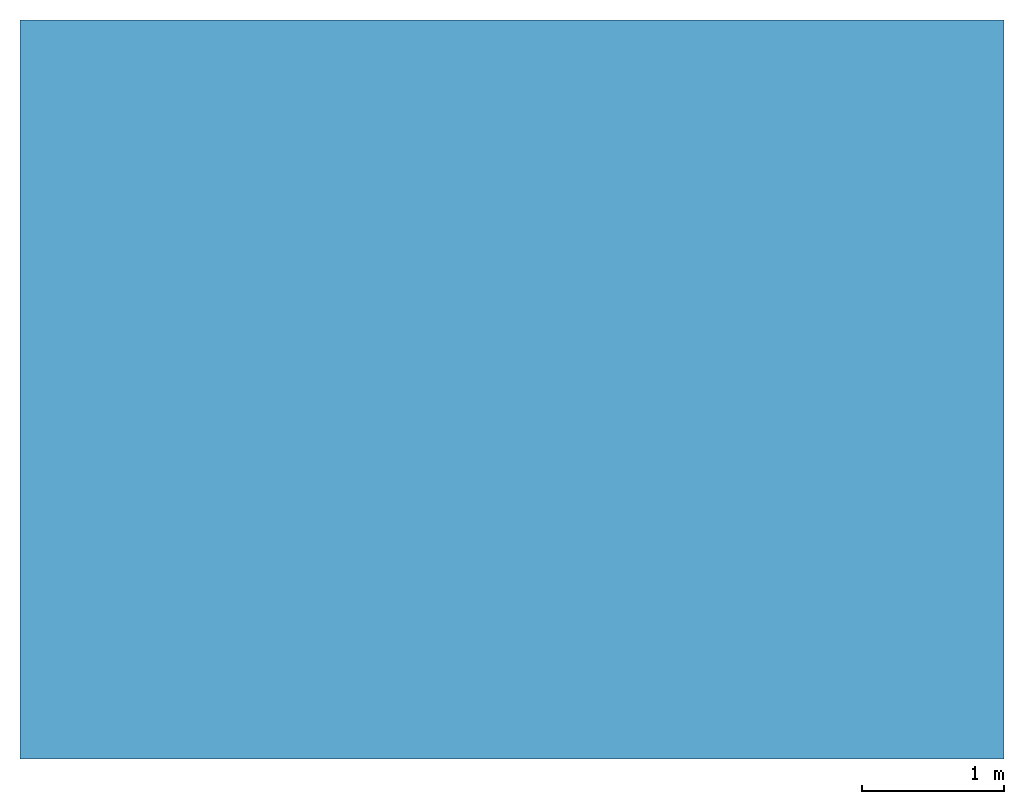
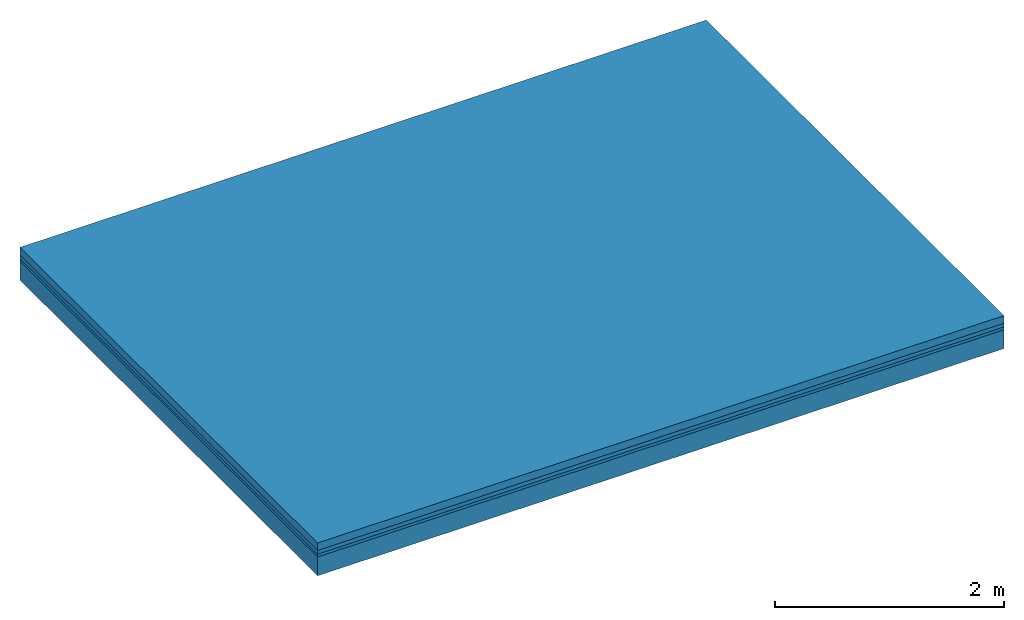
# One storey: 4 building element parts, 1 element without a shape of its own.
"""IFC2X3 building model written with IfcOpenShell, lengths in metres."""

from ifc_helpers import new_model, entity, si_unit, converted_unit, derived_unit, money_unit, direction, frame, origin_with_axes, place, context, subcontext, project, spatial, polyline, outline, extrude, material, type_object, element, aggregate, save


model = new_model("IFC2X3")

# Units and contexts
model_context = context("Model", 3, precision=1e-05, world=origin_with_axes(), true_north=direction((0.309016994375, 0.951056516295)))
body_context = subcontext(model_context, "Body", "Model", "MODEL_VIEW")
ifc_project = project(units=[si_unit("LENGTHUNIT", "METRE"), si_unit("AREAUNIT", "SQUARE_METRE"), si_unit("VOLUMEUNIT", "CUBIC_METRE"), converted_unit("PLANEANGLEUNIT", "DEGREE", entity("IfcPlaneAngleMeasure", 0.0174532925199), si_unit("PLANEANGLEUNIT", "RADIAN"), dimensions=[0, 0, 0, 0, 0, 0, 0]), si_unit("SOLIDANGLEUNIT", "STERADIAN"), money_unit("EUR"), si_unit("TIMEUNIT", "SECOND"), si_unit("MASSUNIT", "GRAM", prefix="KILO"), si_unit("THERMODYNAMICTEMPERATUREUNIT", "DEGREE_CELSIUS"), si_unit("LUMINOUSINTENSITYUNIT", "LUMEN"), si_unit("ENERGYUNIT", "JOULE", prefix="MEGA"), derived_unit("THERMALCONDUCTANCEUNIT", [(si_unit("POWERUNIT", "WATT"), 1), (si_unit("LENGTHUNIT", "METRE"), -1), (si_unit("THERMODYNAMICTEMPERATUREUNIT", "KELVIN"), -1)]), derived_unit("SPECIFICHEATCAPACITYUNIT", [(si_unit("ENERGYUNIT", "JOULE"), 1), (si_unit("MASSUNIT", "GRAM", prefix="KILO"), -1), (si_unit("THERMODYNAMICTEMPERATUREUNIT", "KELVIN"), -1)]), derived_unit("MASSDENSITYUNIT", [(si_unit("MASSUNIT", "GRAM", prefix="KILO"), 1), (si_unit("VOLUMEUNIT", "CUBIC_METRE"), -1)])], contexts=[model_context])

# Site, building, storey
site_placement = place(None, origin_with_axes())
site = spatial("IfcSite", under=ifc_project, at=site_placement, CompositionType="ELEMENT")
building_placement = place(site_placement, origin_with_axes())
building = spatial("IfcBuilding", under=site, at=building_placement, CompositionType="ELEMENT")
storey_placement = place(building_placement, frame((0.0, 0.0, -2.88), z_axis=(0.0, 0.0, 1.0), x_axis=(1.0, 0.0, 0.0)))
storey = spatial("IfcBuildingStorey", under=building, at=storey_placement, Name="1.Untergeschoss", CompositionType="ELEMENT", Elevation=-2.88)

# Slab, building element parts
slab_type = type_object("IfcSlabType", Name="302_Decke allgemein (LOD200) 350", PredefinedType="FLOOR")
slab_placement = place(storey_placement, frame((2.43012829992, 1.40402879337, -0.15), z_axis=(0.0, 0.0, 1.0), x_axis=(1.0, 0.0, 0.0)))
slab = element("IfcSlab", 1, at=slab_placement, inside=storey, type_object=slab_type, PredefinedType="FLOOR")
ifc_material_1 = material(Name="Beton, Stahlbeton Decke")
building_element_part_1_placement = place(slab_placement, origin_with_axes())
building_element_part_1 = element("IfcBuildingElementPart", 2, at=building_element_part_1_placement, material=ifc_material_1, Name="Beton, Stahlbeton Decke", context=body_context, shape_type="SweptSolid", body=[
    extrude(outline(polyline([(0.0, 0.0), (6.91326862204, 0.0), (6.91326862204, 5.19237758183), (0.0, 5.19237758183), (0.0, 0.0)])), frame((0.0, 0.0, -0.2), z_axis=(0.0, 0.0, 1.0), x_axis=(1.0, 0.0, 0.0)), (0.0, 0.0, 1.0), 0.2),
])
ifc_material_2 = material(Name="Boden, Sand")
building_element_part_2_placement = place(slab_placement, origin_with_axes())
building_element_part_2 = element("IfcBuildingElementPart", 3, at=building_element_part_2_placement, material=ifc_material_2, Name="Boden, Sand", context=body_context, shape_type="SweptSolid", body=[
    extrude(outline(polyline([(0.0, 0.0), (6.91326862204, 0.0), (6.91326862204, 5.19237758183), (0.0, 5.19237758183), (0.0, 0.0)])), origin_with_axes(), (0.0, 0.0, 1.0), 0.03),
])
ifc_material_3 = material()
building_element_part_3_placement = place(slab_placement, origin_with_axes())
building_element_part_3 = element("IfcBuildingElementPart", 4, at=building_element_part_3_placement, material=ifc_material_3, context=body_context, shape_type="SweptSolid", body=[
    extrude(outline(polyline([(0.0, 0.0), (6.91326862204, 0.0), (6.91326862204, 5.19237758183), (0.0, 5.19237758183), (0.0, 0.0)])), frame((0.0, 0.0, 0.03), z_axis=(0.0, 0.0, 1.0), x_axis=(1.0, 0.0, 0.0)), (0.0, 0.0, 1.0), 0.04),
])
ifc_material_4 = material(Name="Estrich")
building_element_part_4_placement = place(slab_placement, origin_with_axes())
building_element_part_4 = element("IfcBuildingElementPart", 5, at=building_element_part_4_placement, material=ifc_material_4, Name="Estrich", context=body_context, shape_type="SweptSolid", body=[
    extrude(outline(polyline([(0.0, 0.0), (6.91326862204, 0.0), (6.91326862204, 5.19237758183), (0.0, 5.19237758183), (0.0, 0.0)])), frame((0.0, 0.0, 0.07), z_axis=(0.0, 0.0, 1.0), x_axis=(1.0, 0.0, 0.0)), (0.0, 0.0, 1.0), 0.08),
])
aggregate(slab, [building_element_part_1, building_element_part_2, building_element_part_3, building_element_part_4])

save(model, "model.ifc")
